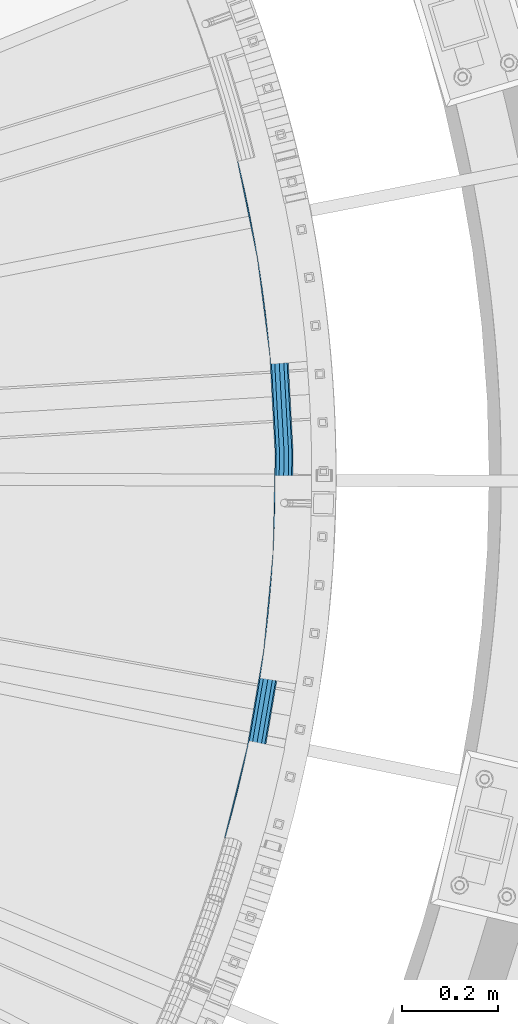
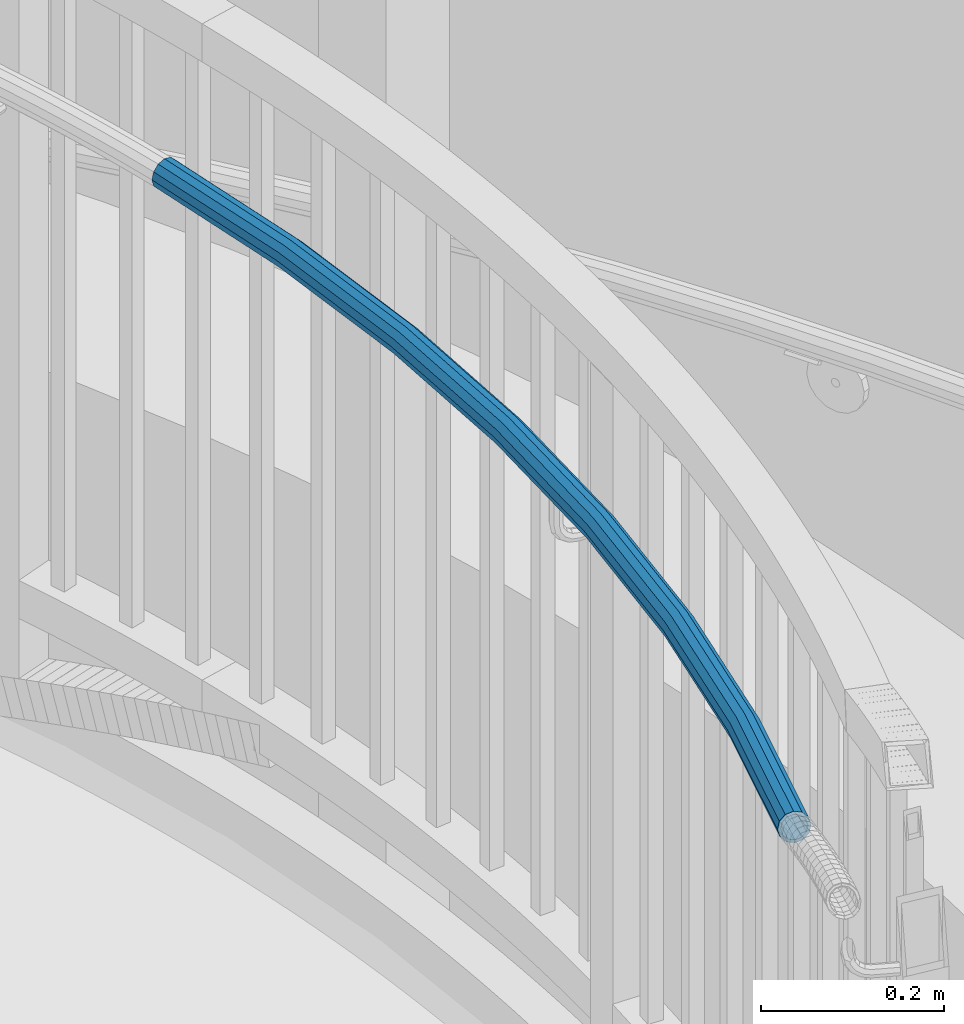
# One storey, part 363 of 975: 1 beam.
"""IFC2X3 building model written with IfcOpenShell, lengths in millimetres."""

import ifcopenshell
import ifcopenshell.guid

model = None  # the IFC model being written
_history = None  # IfcOwnerHistory: only IFC2X3 demands one
_inside = {}  # id of a spatial element -> (the spatial element, [elements in it])
_under = {}  # id of a project, library or spatial element -> (it, [spatial elements below it])
_declared = {}  # id of a project -> (the project, [libraries it declares])
_typed = {}  # id of a type object -> (the type object, [elements of that type])
_made_of = {}  # id of a material, layer set ... -> (it, [elements and type objects made of it])


def new_model(schema):
    """Start an empty IFC model of exactly this schema.

    Asked for "IFC4X3", IfcOpenShell would pick the latest addendum, in which some entities
    have other attributes; the version numbers below select the first issue.
    IFC2X3 requires an IfcOwnerHistory on every rooted entity: one is made here for all.
    """
    global model, _history
    if schema == "IFC4X3":
        model = ifcopenshell.file(schema_version=(4, 3, 0, 0))
    else:
        model = ifcopenshell.file(schema=schema)
    _inside.clear()
    _under.clear()
    _declared.clear()
    _typed.clear()
    _made_of.clear()
    _history = None
    if model.schema == "IFC2X3":
        org = make("IfcOrganization", Name="unknown")
        user = make(
            "IfcPersonAndOrganization",
            ThePerson=make("IfcPerson", FamilyName="unknown"),
            TheOrganization=org,
        )
        app = make(
            "IfcApplication",
            ApplicationDeveloper=org,
            Version="unknown",
            ApplicationFullName="unknown",
            ApplicationIdentifier="unknown",
        )
        _history = make(
            "IfcOwnerHistory",
            OwningUser=user,
            OwningApplication=app,
            ChangeAction="ADDED",
            CreationDate=0,
        )
    return model


def make(cls, **values):
    """One entity of the class cls with the attributes given. An attribute that is None is left unset."""
    return model.create_entity(
        cls, **{name: value for name, value in values.items() if value is not None}
    )


def rooted(cls, **values):
    """An entity with a GlobalId (a new one), such as an element, a storey or a relation."""
    return make(cls, GlobalId=ifcopenshell.guid.new(), OwnerHistory=_history, **values)


def si_unit(unit_type, name, prefix=None):
    """IfcSIUnit, for example si_unit("LENGTHUNIT", "METRE", prefix="MILLI")."""
    return make("IfcSIUnit", UnitType=unit_type, Prefix=prefix, Name=name)


def assignment(units):
    """IfcUnitAssignment: the units of a project."""
    return None if units is None else make("IfcUnitAssignment", Units=units)


def point(xyz):
    """IfcCartesianPoint."""
    return None if xyz is None else make("IfcCartesianPoint", Coordinates=xyz)


def direction(xyz):
    """IfcDirection."""
    return None if xyz is None else make("IfcDirection", DirectionRatios=xyz)


def frame(location, z_axis=None, x_axis=None):
    """IfcAxis2Placement3D, a coordinate frame: its origin and axes. An axis left out is left unset."""
    return make(
        "IfcAxis2Placement3D",
        Location=point(location),
        Axis=direction(z_axis),
        RefDirection=direction(x_axis),
    )


def origin_with_axes():
    """The frame at (0, 0, 0) with the z axis (0, 0, 1) and the x axis (1, 0, 0) written out."""
    return frame((0.0, 0.0, 0.0), z_axis=(0.0, 0.0, 1.0), x_axis=(1.0, 0.0, 0.0))


def place(relative_to, where):
    """IfcLocalPlacement: puts the frame where relative to a parent placement (None: the world)."""
    return make(
        "IfcLocalPlacement", PlacementRelTo=relative_to, RelativePlacement=where
    )


def context(
    kind, dimensions, precision=None, world=None, true_north=None, identifier=None
):
    """IfcGeometricRepresentationContext, for example the 3D "Model" context."""
    return make(
        "IfcGeometricRepresentationContext",
        ContextIdentifier=identifier,
        ContextType=kind,
        CoordinateSpaceDimension=dimensions,
        Precision=precision,
        WorldCoordinateSystem=world,
        TrueNorth=true_north,
    )


def subcontext(parent, identifier, kind, view, scale=None):
    """IfcGeometricRepresentationSubContext, for example "Body" below "Model"."""
    return make(
        "IfcGeometricRepresentationSubContext",
        ContextIdentifier=identifier,
        ContextType=kind,
        ParentContext=parent,
        TargetScale=scale,
        TargetView=view,
    )


def project(units=None, contexts=None):
    """IfcProject with its units and contexts."""
    return rooted(
        "IfcProject",
        Name="project",
        RepresentationContexts=contexts,
        UnitsInContext=assignment(units),
    )


def spatial(cls, under=None, at=None, **own):
    """A site, building, storey or space (cls), placed at a placement, below another one or the project."""
    s = rooted(cls, ObjectPlacement=at, **own)
    if under is not None:
        _under.setdefault(under.id(), (under, []))[1].append(s)
    return s


def faces_of(points, faces, orient=None, outer=None):
    """IfcFace entities. A face is a list of loops; a loop is a list of indices into points, from 0.

    orient and outer hold one flag for each loop. By default every Orientation is true, the
    first loop of a face is its IfcFaceOuterBound and the others are IfcFaceBound.
    """
    made = []
    for i, loops in enumerate(faces):
        bounds = []
        for j, loop in enumerate(loops):
            is_outer = j == 0 if outer is None else outer[i][j]
            bounds.append(
                make(
                    "IfcFaceOuterBound" if is_outer else "IfcFaceBound",
                    Bound=make("IfcPolyLoop", Polygon=[points[k] for k in loop]),
                    Orientation=True if orient is None else orient[i][j],
                )
            )
        made.append(make("IfcFace", Bounds=bounds))
    return made


def faceted_brep(points, faces, orient=None, outer=None, voids=None):
    """IfcFacetedBrep: a solid bounded by flat faces; with voids (closed shells), ...WithVoids."""
    shared = [point(p) for p in points]
    hull = make("IfcClosedShell", CfsFaces=faces_of(shared, faces, orient, outer))
    if voids is None:
        return make("IfcFacetedBrep", Outer=hull)
    return make(
        "IfcFacetedBrepWithVoids",
        Outer=hull,
        Voids=[
            make(cls, CfsFaces=faces_of(shared, fs, o, b)) for cls, fs, o, b in voids
        ],
    )


def shape(context_of_items, identifier, shape_type, items):
    """IfcShapeRepresentation: the items that make up one representation, for example the "Body"."""
    return make(
        "IfcShapeRepresentation",
        ContextOfItems=context_of_items,
        RepresentationIdentifier=identifier,
        RepresentationType=shape_type,
        Items=items,
    )


def material(Name=None, Category=None):
    """IfcMaterial."""
    return make("IfcMaterial", Name=Name, Category=Category)


def made_of(thing, what):
    """Note that an element or type object is made of a material, layer set ...; save() writes the relation."""
    if what is not None:
        _made_of.setdefault(what.id(), (what, []))[1].append(thing)
    return thing


def type_object(cls, material=None, **own):
    """A type object (cls), such as IfcWallType, which elements share."""
    return made_of(rooted(cls, **own), material)


def element(
    cls,
    number,
    at=None,
    inside=None,
    cuts=None,
    type_object=None,
    material=None,
    context=None,
    identifier="Body",
    shape_type=None,
    held_by="IfcProductDefinitionShape",
    body=None,
    shapes=None,
    **own,
):
    """One element of the class cls, such as IfcWall. Its Tag is "e" and its number.

    at: its placement. inside: the storey or other place that contains it. cuts: it is an
    opening in that element (IfcRelVoidsElement). A single representation is given by context,
    identifier, shape_type and body (its items); several are given by shapes. held_by: the class
    of the entity that holds the representations. save() writes the other relations.
    """
    e = rooted(cls, Tag="e%d" % number, ObjectPlacement=at, **own)
    if body is not None:
        shapes = [shape(context, identifier, shape_type, body)]
    if shapes is not None:
        e.Representation = make(held_by, Representations=shapes)
    if inside is not None:
        _inside.setdefault(inside.id(), (inside, []))[1].append(e)
    if cuts is not None:
        rooted(
            "IfcRelVoidsElement", RelatingBuildingElement=cuts, RelatedOpeningElement=e
        )
    if type_object is not None:
        _typed.setdefault(type_object.id(), (type_object, []))[1].append(e)
    return made_of(e, material)


def aggregate(whole, parts):
    """IfcRelAggregates: a whole, such as a stair, and the parts it consists of."""
    return rooted("IfcRelAggregates", RelatingObject=whole, RelatedObjects=parts)


def save(model, path):
    """Write the relations noted so far, then the file.

    IfcRelAggregates (storeys below a building ...), IfcRelContainedInSpatialStructure (elements
    in a storey), IfcRelDefinesByType, IfcRelAssociatesMaterial and IfcRelDeclares: one each for
    every whole, place, type object, material and project.
    """
    for whole, parts in _under.values():
        aggregate(whole, parts)
    for where, things in _inside.values():
        rooted(
            "IfcRelContainedInSpatialStructure",
            RelatedElements=things,
            RelatingStructure=where,
        )
    for kind, things in _typed.values():
        rooted("IfcRelDefinesByType", RelatedObjects=things, RelatingType=kind)
    for what, things in _made_of.values():
        rooted("IfcRelAssociatesMaterial", RelatedObjects=things, RelatingMaterial=what)
    for by, libraries in _declared.values():
        rooted("IfcRelDeclares", RelatingContext=by, RelatedDefinitions=libraries)
    model.write(path)


model = new_model("IFC2X3")

# Units and contexts
model_context = context("Model", 3, precision=1e-05, world=origin_with_axes())
body_context = subcontext(model_context, "Body", "Model", "MODEL_VIEW")
ifc_project = project(units=[si_unit("LENGTHUNIT", "METRE", prefix="MILLI"), si_unit("AREAUNIT", "SQUARE_METRE"), si_unit("VOLUMEUNIT", "CUBIC_METRE"), si_unit("MASSUNIT", "GRAM", prefix="KILO"), si_unit("TIMEUNIT", "SECOND"), si_unit("PLANEANGLEUNIT", "RADIAN"), si_unit("SOLIDANGLEUNIT", "STERADIAN"), si_unit("THERMODYNAMICTEMPERATUREUNIT", "DEGREE_CELSIUS"), si_unit("LUMINOUSINTENSITYUNIT", "LUMEN")], contexts=[model_context])

# Site, building, storey
site_placement = place(None, origin_with_axes())
site = spatial("IfcSite", under=ifc_project, at=site_placement, CompositionType="ELEMENT")
building_placement = place(site_placement, origin_with_axes())
building = spatial("IfcBuilding", under=site, at=building_placement, Name="Undefined", CompositionType="ELEMENT")
storey_placement = place(building_placement, origin_with_axes())
storey = spatial("IfcBuildingStorey", under=building, at=storey_placement, Name="Undefined", CompositionType="ELEMENT", Elevation=0.0)

# Beam
ifc_material = material()
beam_type = type_object("IfcBeamType", PredefinedType="NOTDEFINED")
beam_placement = place(storey_placement, frame((37442.4306561969, 4065.49434195752, 3028.95), z_axis=(0.0, 0.0, 1.0), x_axis=(-0.131873471040866, -0.991266557307182, 0.0)))
element("IfcBeam", 1, at=beam_placement, inside=storey, type_object=beam_type, material=ifc_material, Name="HANDRAIL", context=body_context, shape_type="Brep", body=[
    faceted_brep([(5.99639505312371, -15.3694541661971, -9.52500000000009), (3.46202029808774, -8.87355850015592, -16.4977839420935), (198.626815447567, 59.0209905715456, -16.4977839420935), (200.671348330952, 52.3546871587168, -9.52500000000009), (398.298256935632, 112.221390132887, -16.4977839420935), (399.841636767624, 105.421559649898, -9.52500000000009), (601.371681891613, 150.433314136717, -16.4977839420935), (602.405370073086, 143.537575985756, -9.52500000000009), (806.723606301492, 173.445358822202, -16.4977839420935), (807.241884052906, 166.491863005314, -9.52500000000009), (1013.21794057416, 181.130212285578, -16.4977839420935), (1013.21794057416, 174.157428343489, -9.52500000000009), (1219.71227484684, 173.445358820936, -16.4977839420935), (1219.19399709542, 166.491863004048, -9.52500000000009), (1013.21794057416, 190.655212285579, -19.0500000000002), (1220.42025542149, 182.944010751904, -19.0500000000002), (806.015625726843, 182.944010753177, -19.0500000000002), (599.95963757613, 159.85306762877, -19.0500000000002), (396.189960877442, 121.510131314062, -19.0500000000002), (195.83393158999, 68.1273303828129, -19.0500000000002), (-3.63797880709171e-12, 3.63797880709171e-12, -19.0500000000002), (-3.46202029809137, 8.8735585001632, -16.4977839420935), (193.041047732413, 77.2336701940658, -16.4977839420935), (394.081664819252, 130.798872495252, -16.4977839420935), (598.547593260644, 169.27282112083, -16.4977839420935), (805.307645152193, 192.442662684152, -16.4977839420935), (1013.21794057416, 200.180212285566, -16.4977839420935), (1221.12823599614, 192.442662682872, -16.4977839420935), (1013.21794057416, 207.152996227655, -9.52500000000009), (1221.64651374755, 199.39615849976, -9.52500000000009), (804.789367400778, 199.39615850104, -9.52500000000009), (597.513905079173, 176.168559271784, -9.52500000000009), (392.53828498726, 137.598702978234, -9.52500000000009), (190.996514849028, 83.8999736068945, -9.52500000000009), (-5.99639505312734, 15.3694541662117, -9.52500000000009), (-6.92404059618093, 17.7471170003191, 0.0), (190.248163874836, 86.3400100053259, 0.0), (391.973368761062, 140.087613676435, 0.0), (597.135548945162, 178.692574612884, 0.0), (804.599664577543, 201.941314615135, 0.0), (1013.21794057416, 209.705212285568, 0.0), (1221.83621657078, 201.941314613839, 0.0), (1013.21794057416, 207.152996227655, 9.52500000000009), (1221.64651374755, 199.39615849976, 9.52500000000009), (804.789367400778, 199.39615850104, 9.52500000000009), (597.513905079173, 176.168559271784, 9.52500000000009), (392.53828498726, 137.598702978234, 9.52500000000009), (190.996514849028, 83.8999736068945, 9.52500000000009), (-5.99639505312734, 15.3694541662117, 9.52500000000009), (-3.46202029809137, 8.8735585001632, 16.4977839420935), (193.041047732413, 77.2336701940658, 16.4977839420935), (394.081664819252, 130.798872495252, 16.4977839420935), (598.547593260644, 169.27282112083, 16.4977839420935), (805.307645152193, 192.442662684152, 16.4977839420935), (1013.21794057416, 200.180212285566, 16.4977839420935), (1221.12823599614, 192.442662682872, 16.4977839420935), (1013.21794057416, 190.655212285579, 19.0500000000002), (1220.42025542149, 182.944010751904, 19.0500000000002), (806.015625726843, 182.944010753177, 19.0500000000002), (599.95963757613, 159.85306762877, 19.0500000000002), (396.189960877442, 121.510131314062, 19.0500000000002), (195.83393158999, 68.1273303828129, 19.0500000000002), (-3.63797880709171e-12, 3.63797880709171e-12, 19.0500000000002), (3.46202029808774, -8.87355850015592, 16.4977839420935), (198.626815447567, 59.0209905715456, 16.4977839420935), (398.298256935632, 112.221390132887, 16.4977839420935), (601.371681891613, 150.433314136717, 16.4977839420935), (806.723606301492, 173.445358822202, 16.4977839420935), (1013.21794057416, 181.130212285578, 16.4977839420935), (1219.71227484684, 173.445358820936, 16.4977839420935), (1013.21794057416, 174.157428343489, 9.52500000000009), (1219.19399709542, 166.491863004048, 9.52500000000009), (807.241884052906, 166.491863005314, 9.52500000000009), (602.405370073086, 143.537575985756, 9.52500000000009), (399.841636767624, 105.421559649898, 9.52500000000009), (200.671348330952, 52.3546871587168, 9.52500000000009), (5.99639505312371, -15.3694541661971, 9.52500000000009), (6.92404059617729, -17.7471170003046, 0.0), (201.419699305145, 49.9146507602854, 0.0), (400.406552993822, 102.93264895169, 0.0), (602.783726207095, 141.013560644657, 0.0), (807.43158687614, 163.946706891234, 0.0), (1013.21794057416, 171.605212285591, 0.0), (1219.00429427219, 163.946706889954, 0.0), (1413.07555250127, 142.198790576957, 0.0), (1411.93872018067, 144.892600209118, 9.52500000000009), (1411.83828517476, 151.915429905683, 16.4977839420935), (1412.80115896227, 161.385518120878, 19.0500000000002), (1414.56934028942, 170.765362365171, 16.4977839420935), (1416.66904639753, 177.541640948184, 9.52500000000009), (1418.53766273059, 179.898655495919, 0.0), (1419.67449505119, 177.204845863744, -9.52500000000009), (1419.7749300571, 170.182016167171, -16.4977839420935), (1418.81205626959, 160.71192795199, -19.0500000000002), (1417.04387494243, 151.33208370769, -16.4977839420935), (1414.94416883432, 144.555805124677, -9.52500000000009), (4.83709200952035, -12.39802636073, -7.68350000000009), (2.79269637379002, -7.15800385679177, -13.3082123799554), (-3.63797880709171e-12, 3.63797880709171e-12, -15.3670000000002), (-2.79269637379366, 7.15800385679904, -13.3082123799554), (-4.83709200952399, 12.3980263607446, -7.68350000000009), (-5.58539274758732, 14.3160077135981, 0.0), (-4.83709200952399, 12.3980263607446, 7.68350000000009), (-2.79269637379366, 7.15800385679904, 13.3082123799554), (-3.63797880709171e-12, 3.63797880709171e-12, 15.3670000000002), (2.79269637379002, -7.15800385679177, 13.3082123799554), (4.83709200952035, -12.39802636073, 7.68350000000009), (5.58539274758186, -14.3160077135835, 0.0), (199.7361144277, 55.4040648487135, 7.68350000000009), (200.339784213549, 53.4357688206437, 0.0), (199.7361144277, 55.4040648487135, -7.68350000000009), (198.08685790177, 60.7815496017283, -13.3082123799554), (195.83393158999, 68.1273303828129, -15.3670000000002), (193.581005278211, 75.4731111638976, -13.3082123799554), (191.93174875228, 80.8505959169051, -7.68350000000009), (191.328078966433, 82.8188919449749, 0.0), (191.93174875228, 80.8505959169051, 7.68350000000009), (193.581005278211, 75.4731111638976, 13.3082123799554), (195.83393158999, 68.1273303828129, 15.3670000000002), (198.08685790177, 60.7815496017283, 13.3082123799554), (397.890653031047, 114.017213427913, 13.3082123799554), (399.135646095521, 108.532016838304, 7.68350000000009), (399.591345184655, 106.524295541756, 0.0), (399.135646095521, 108.532016838304, -7.68350000000009), (397.890653031047, 114.017213427913, -13.3082123799554), (396.189960877442, 121.510131314062, -15.3670000000002), (394.489268723835, 129.003049200226, -13.3082123799554), (393.244275659363, 134.488245789835, -7.68350000000009), (392.78857657023, 136.495967086375, 0.0), (393.244275659363, 134.488245789835, 7.68350000000009), (394.489268723835, 129.003049200226, 13.3082123799554), (396.189960877442, 121.510131314062, 15.3670000000002), (599.95963757613, 159.85306762877, 15.3670000000002), (601.098686657284, 152.254466478516, 13.3082123799554), (601.932528457006, 146.691904370084, 7.68350000000009), (602.237735738441, 144.655865328255, 0.0), (601.932528457006, 146.691904370084, -7.68350000000009), (601.098686657284, 152.254466478516, -13.3082123799554), (599.95963757613, 159.85306762877, -15.3670000000002), (598.820588494973, 167.451668779031, -13.3082123799554), (597.986746695251, 173.014230887464, -7.68350000000009), (597.681539413816, 175.050269929292, 0.0), (597.986746695251, 173.014230887464, 7.68350000000009), (598.820588494973, 167.451668779031, 13.3082123799554), (805.444521396625, 190.606256644169, 13.3082123799554), (806.015625726843, 182.944010753177, 15.3670000000002), (806.586730057059, 175.281764862193, 13.3082123799554), (807.004807443201, 169.672611569906, 7.68350000000009), (807.157834387277, 167.619518971202, 0.0), (807.004807443201, 169.672611569906, -7.68350000000009), (806.586730057059, 175.281764862193, -13.3082123799554), (806.015625726843, 182.944010753177, -15.3670000000002), (805.444521396626, 190.606256644161, -13.3082123799554), (805.026444010484, 196.215409936456, -7.68350000000009), (804.873417066407, 198.268502535153, 0.0), (805.026444010484, 196.215409936456, 7.68350000000009), (1013.21794057416, 203.963424665526, 7.68350000000009), (1013.21794057416, 198.338712285571, 13.3082123799554), (1013.21794057416, 190.655212285579, 15.3670000000002), (1013.21794057416, 182.97171228558, 13.3082123799554), (1013.21794057416, 177.346999905625, 7.68350000000009), (1013.21794057416, 175.288212285588, 0.0), (1013.21794057416, 177.346999905625, -7.68350000000009), (1013.21794057416, 182.97171228558, -13.3082123799554), (1013.21794057416, 190.655212285579, -15.3670000000002), (1013.21794057416, 198.338712285571, -13.3082123799554), (1013.21794057416, 203.963424665526, -7.68350000000009), (1013.21794057416, 206.02221228557, 0.0), (1221.56246408192, 198.268502533872, 0.0), (1221.40943713785, 196.215409935168, 7.68350000000009), (1220.9913597517, 190.606256642888, 13.3082123799554), (1220.42025542149, 182.944010751904, 15.3670000000002), (1219.84915109127, 175.28176486092, 13.3082123799554), (1219.43107370513, 169.672611568632, 7.68350000000009), (1219.27804676105, 167.619518969936, 0.0), (1219.43107370513, 169.672611568632, -7.68350000000009), (1219.84915109127, 175.28176486092, -13.3082123799554), (1220.42025542149, 182.944010751904, -15.3670000000002), (1220.9913597517, 190.606256642888, -13.3082123799554), (1221.40943713785, 196.215409935168, -7.68350000000009), (1418.92670348037, 174.081328783795, -7.68350000000009), (1418.00965874176, 176.254335220416, 0.0), (1416.50230823309, 174.353010151914, 7.68350000000009), (1414.80854530588, 168.886812094948, 13.3082123799554), (1413.38221236864, 161.320404404549, 15.3670000000002), (1412.60549418005, 153.68119991097, 13.3082123799554), (1412.68651175148, 148.016117289066, 7.68350000000009), (1413.6035564901, 145.843110852453, 0.0), (1415.11090699877, 147.744435920948, -7.68350000000009), (1416.80466992598, 153.210633977913, -13.3082123799554), (1418.23100286321, 160.77704166832, -15.3670000000002), (1419.0077210518, 168.416246161905, -13.3082123799554)], [[[0, 1, 2, 3]], [[3, 2, 4, 5]], [[5, 4, 6, 7]], [[7, 6, 8, 9]], [[9, 8, 10, 11]], [[11, 10, 12, 13]], [[10, 14, 15, 12]], [[8, 16, 14, 10]], [[6, 17, 16, 8]], [[4, 18, 17, 6]], [[2, 19, 18, 4]], [[1, 20, 19, 2]], [[20, 21, 22, 19]], [[19, 22, 23, 18]], [[18, 23, 24, 17]], [[17, 24, 25, 16]], [[16, 25, 26, 14]], [[14, 26, 27, 15]], [[26, 28, 29, 27]], [[25, 30, 28, 26]], [[24, 31, 30, 25]], [[23, 32, 31, 24]], [[22, 33, 32, 23]], [[21, 34, 33, 22]], [[34, 35, 36, 33]], [[33, 36, 37, 32]], [[32, 37, 38, 31]], [[31, 38, 39, 30]], [[30, 39, 40, 28]], [[28, 40, 41, 29]], [[40, 42, 43, 41]], [[39, 44, 42, 40]], [[38, 45, 44, 39]], [[37, 46, 45, 38]], [[36, 47, 46, 37]], [[35, 48, 47, 36]], [[48, 49, 50, 47]], [[47, 50, 51, 46]], [[46, 51, 52, 45]], [[45, 52, 53, 44]], [[44, 53, 54, 42]], [[42, 54, 55, 43]], [[54, 56, 57, 55]], [[53, 58, 56, 54]], [[52, 59, 58, 53]], [[51, 60, 59, 52]], [[50, 61, 60, 51]], [[49, 62, 61, 50]], [[62, 63, 64, 61]], [[61, 64, 65, 60]], [[60, 65, 66, 59]], [[59, 66, 67, 58]], [[58, 67, 68, 56]], [[56, 68, 69, 57]], [[68, 70, 71, 69]], [[67, 72, 70, 68]], [[66, 73, 72, 67]], [[65, 74, 73, 66]], [[64, 75, 74, 65]], [[63, 76, 75, 64]], [[76, 77, 78, 75]], [[75, 78, 79, 74]], [[74, 79, 80, 73]], [[73, 80, 81, 72]], [[72, 81, 82, 70]], [[70, 82, 83, 71]], [[71, 83, 84, 85]], [[69, 71, 85, 86]], [[57, 69, 86, 87]], [[55, 57, 87, 88]], [[43, 55, 88, 89]], [[41, 43, 89, 90]], [[29, 41, 90, 91]], [[27, 29, 91, 92]], [[15, 27, 92, 93]], [[12, 15, 93, 94]], [[13, 12, 94, 95]], [[83, 13, 95, 84]], [[82, 11, 13, 83]], [[81, 9, 11, 82]], [[80, 7, 9, 81]], [[79, 5, 7, 80]], [[78, 3, 5, 79]], [[77, 0, 3, 78]], [[76, 63, 62, 49, 48, 35, 34, 21, 20, 1, 0, 77], [96, 97, 98, 99, 100, 101, 102, 103, 104, 105, 106, 107]], [[107, 106, 108, 109]], [[96, 107, 109, 110]], [[97, 96, 110, 111]], [[98, 97, 111, 112]], [[99, 98, 112, 113]], [[100, 99, 113, 114]], [[101, 100, 114, 115]], [[102, 101, 115, 116]], [[103, 102, 116, 117]], [[104, 103, 117, 118]], [[105, 104, 118, 119]], [[106, 105, 119, 108]], [[108, 119, 120, 121]], [[109, 108, 121, 122]], [[110, 109, 122, 123]], [[111, 110, 123, 124]], [[112, 111, 124, 125]], [[113, 112, 125, 126]], [[114, 113, 126, 127]], [[115, 114, 127, 128]], [[116, 115, 128, 129]], [[117, 116, 129, 130]], [[118, 117, 130, 131]], [[119, 118, 131, 120]], [[120, 131, 132, 133]], [[121, 120, 133, 134]], [[122, 121, 134, 135]], [[123, 122, 135, 136]], [[124, 123, 136, 137]], [[125, 124, 137, 138]], [[126, 125, 138, 139]], [[127, 126, 139, 140]], [[128, 127, 140, 141]], [[129, 128, 141, 142]], [[130, 129, 142, 143]], [[131, 130, 143, 132]], [[132, 143, 144, 145]], [[133, 132, 145, 146]], [[134, 133, 146, 147]], [[135, 134, 147, 148]], [[136, 135, 148, 149]], [[137, 136, 149, 150]], [[138, 137, 150, 151]], [[139, 138, 151, 152]], [[140, 139, 152, 153]], [[141, 140, 153, 154]], [[142, 141, 154, 155]], [[143, 142, 155, 144]], [[144, 155, 156, 157]], [[145, 144, 157, 158]], [[146, 145, 158, 159]], [[147, 146, 159, 160]], [[148, 147, 160, 161]], [[149, 148, 161, 162]], [[150, 149, 162, 163]], [[151, 150, 163, 164]], [[152, 151, 164, 165]], [[153, 152, 165, 166]], [[154, 153, 166, 167]], [[155, 154, 167, 156]], [[156, 167, 168, 169]], [[157, 156, 169, 170]], [[158, 157, 170, 171]], [[159, 158, 171, 172]], [[160, 159, 172, 173]], [[161, 160, 173, 174]], [[162, 161, 174, 175]], [[163, 162, 175, 176]], [[164, 163, 176, 177]], [[165, 164, 177, 178]], [[166, 165, 178, 179]], [[167, 166, 179, 168]], [[168, 179, 180, 181]], [[169, 168, 181, 182]], [[170, 169, 182, 183]], [[171, 170, 183, 184]], [[172, 171, 184, 185]], [[173, 172, 185, 186]], [[174, 173, 186, 187]], [[175, 174, 187, 188]], [[176, 175, 188, 189]], [[177, 176, 189, 190]], [[178, 177, 190, 191]], [[179, 178, 191, 180]], [[89, 88, 87, 86, 85, 84, 95, 94, 93, 92, 91, 90], [190, 189, 188, 187, 186, 185, 184, 183, 182, 181, 180, 191]]]),
])

save(model, "model.ifc")
